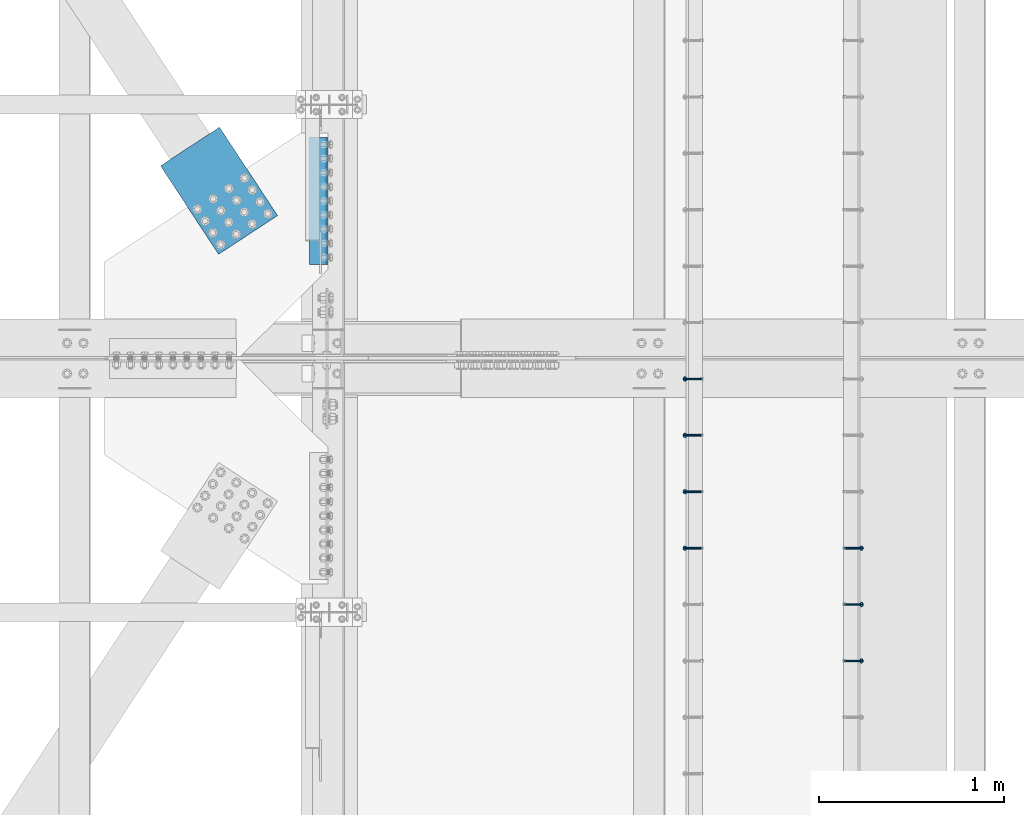
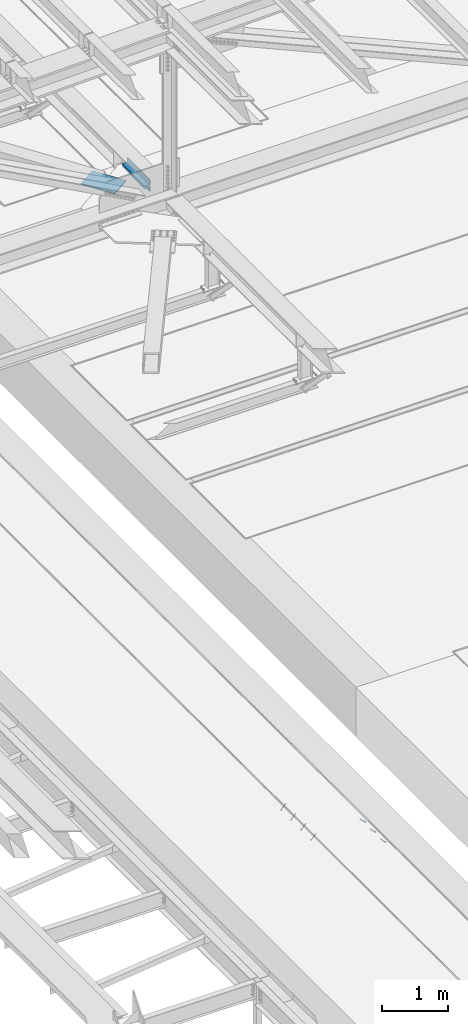
# One storey, part 2203 of 3843: 7 members, 3 beams, 4 elements without a shape of their own.
"""IFC2X3 building model written with IfcOpenShell, lengths in millimetres."""

from ifc_helpers import new_model, si_unit, frame, origin_with_axes, place, context, subcontext, project, spatial, faceted_brep, material, type_object, element, aggregate, save


model = new_model("IFC2X3")

# Units and contexts
model_context = context("Model", 3, precision=1e-05, world=origin_with_axes())
body_context = subcontext(model_context, "Body", "Model", "MODEL_VIEW")
ifc_project = project(units=[si_unit("LENGTHUNIT", "METRE", prefix="MILLI"), si_unit("AREAUNIT", "SQUARE_METRE"), si_unit("VOLUMEUNIT", "CUBIC_METRE"), si_unit("MASSUNIT", "GRAM", prefix="KILO"), si_unit("TIMEUNIT", "SECOND"), si_unit("PLANEANGLEUNIT", "RADIAN"), si_unit("SOLIDANGLEUNIT", "STERADIAN"), si_unit("THERMODYNAMICTEMPERATUREUNIT", "DEGREE_CELSIUS"), si_unit("LUMINOUSINTENSITYUNIT", "LUMEN")], contexts=[model_context])

# Site, building, storey
site_placement = place(None, origin_with_axes())
site = spatial("IfcSite", under=ifc_project, at=site_placement, CompositionType="ELEMENT")
building_placement = place(site_placement, origin_with_axes())
building = spatial("IfcBuilding", under=site, at=building_placement, Name="Undefined", CompositionType="ELEMENT")
storey_placement = place(building_placement, origin_with_axes())
storey = spatial("IfcBuildingStorey", under=building, at=storey_placement, Name="Undefined", CompositionType="ELEMENT", Elevation=0.0)

# Assembly, members
assembly_1_placement = place(storey_placement, origin_with_axes())
assembly_1 = element("IfcElementAssembly", 1, at=assembly_1_placement, inside=storey, Name="EMBED_ANGLE", AssemblyPlace="NOTDEFINED", PredefinedType="RIGID_FRAME")
ifc_material_1 = material(Name="STEEL/A108")
member_type = type_object("IfcMemberType", PredefinedType="NOTDEFINED")
member_1_placement = place(assembly_1_placement, frame((44851.3834999999, 48923.575189209, 30456.1875), z_axis=(0.0, 1.0, 0.0), x_axis=(0.707106781186548, 0.0, -0.707106781186548)))
member_1 = element("IfcMember", 2, at=member_1_placement, type_object=member_type, material=ifc_material_1, Name="HEADED STUD ANCHOR", context=body_context, shape_type="Brep", body=[
    faceted_brep([(7.27595761418343e-12, -3.18000006675175, 5.5), (0.0, -5.49999999998363, 3.1800000667572), (118.110000000976, -5.49999999999091, 3.1800000667572), (118.110000000983, -3.18000006675175, 5.5), (0.0, -6.3499999046162, 0.0), (118.110000000968, -6.34999990461256, 0.0), (0.0, -5.49999999998363, -3.1800000667572), (118.110000000976, -5.49999999999091, -3.1800000667572), (7.27595761418343e-12, -3.18000006675175, -5.5), (118.110000000983, -3.18000006675175, -5.5), (7.27595761418343e-12, -1.81898940354586e-12, -6.34999990463257), (118.110000000968, -1.81898940354586e-12, -6.34999990463257), (0.0, 3.18000006675175, -5.5), (118.110000000968, 3.18000006674811, -5.5), (7.27595761418343e-12, 5.49999999998363, -3.1800000667572), (118.110000000983, 5.49999999998363, -3.1800000667572), (7.27595761418343e-12, 6.3499999046162, 0.0), (118.110000000976, 6.34999990461256, 0.0), (7.27595761418343e-12, 5.49999999998363, 3.1800000667572), (118.110000000983, 5.49999999998363, 3.1800000667572), (0.0, 3.18000006675175, 5.5), (118.110000000968, 3.18000006674811, 5.5), (7.27595761418343e-12, -1.81898940354586e-12, 6.34999990463257), (118.110000000968, -1.81898940354586e-12, 6.34999990463257), (120.650000000991, -10.9899997710909, 6.34999990463257), (120.650000000998, -6.34000015257152, 10.9899997711182), (120.650000000991, -12.6999998092379, 0.0), (120.650000000991, -10.9899997710909, -6.34999990463257), (120.650000000998, -6.34000015257152, -10.9899997711182), (120.650000000991, -1.81898940354586e-12, -12.6899995803833), (120.650000000991, 6.34000015257152, -10.9899997711182), (120.650000000998, 10.9899997710909, -6.34999990463257), (120.650000000991, 12.6999998092342, 0.0), (120.650000000998, 10.9899997710909, 6.34999990463257), (120.650000000991, 6.34000015257152, 10.9899997711182), (120.650000000991, -1.81898940354586e-12, 12.6899995803833), (127.000000001048, -10.9899997710945, 6.34999990463257), (127.000000001048, -6.34000015257152, 10.9899997711182), (127.000000001048, -12.6999998092342, 0.0), (127.000000001048, -10.9899997710945, -6.34999990463257), (127.000000001048, -6.34000015257152, -10.9899997711182), (127.000000001048, 1.81898940354586e-12, -12.6899995803833), (127.000000001048, 6.34000015256788, -10.9899997711182), (127.000000001048, 10.9899997710909, -6.34999990463257), (127.000000001048, 12.6999998092379, 0.0), (127.000000001048, 10.9899997710909, 6.34999990463257), (127.000000001048, 6.34000015256788, 10.9899997711182), (127.000000001048, 1.81898940354586e-12, 12.6899995803833)], [[[0, 1, 2, 3]], [[1, 4, 5, 2]], [[4, 6, 7, 5]], [[6, 8, 9, 7]], [[8, 10, 11, 9]], [[10, 12, 13, 11]], [[12, 14, 15, 13]], [[14, 16, 17, 15]], [[16, 18, 19, 17]], [[18, 20, 21, 19]], [[20, 22, 23, 21]], [[22, 0, 3, 23]], [[22, 20, 18, 16, 14, 12, 10, 8, 6, 4, 1, 0]], [[3, 2, 24, 25]], [[2, 5, 26, 24]], [[5, 7, 27, 26]], [[7, 9, 28, 27]], [[9, 11, 29, 28]], [[11, 13, 30, 29]], [[13, 15, 31, 30]], [[15, 17, 32, 31]], [[17, 19, 33, 32]], [[19, 21, 34, 33]], [[21, 23, 35, 34]], [[23, 3, 25, 35]], [[25, 24, 36, 37]], [[24, 26, 38, 36]], [[26, 27, 39, 38]], [[27, 28, 40, 39]], [[28, 29, 41, 40]], [[29, 30, 42, 41]], [[30, 31, 43, 42]], [[31, 32, 44, 43]], [[32, 33, 45, 44]], [[33, 34, 46, 45]], [[34, 35, 47, 46]], [[35, 25, 37, 47]], [[38, 39, 40, 41, 42, 43, 44, 45, 46, 47, 37, 36]]]),
])
member_2_placement = place(assembly_1_placement, frame((44851.3834999999, 49228.375189209, 30456.1875), z_axis=(0.0, 1.0, 0.0), x_axis=(0.707106781186548, 0.0, -0.707106781186548)))
member_2 = element("IfcMember", 3, at=member_2_placement, type_object=member_type, material=ifc_material_1, Name="HEADED STUD ANCHOR", context=body_context, shape_type="Brep", body=[
    faceted_brep([(7.27595761418343e-12, -3.18000006675175, 5.5), (0.0, -5.49999999998363, 3.1800000667572), (118.110000000976, -5.49999999999091, 3.1800000667572), (118.110000000983, -3.18000006675175, 5.5), (0.0, -6.3499999046162, 0.0), (118.110000000968, -6.34999990461256, 0.0), (0.0, -5.49999999998363, -3.1800000667572), (118.110000000976, -5.49999999999091, -3.1800000667572), (7.27595761418343e-12, -3.18000006675175, -5.5), (118.110000000983, -3.18000006675175, -5.5), (7.27595761418343e-12, -1.81898940354586e-12, -6.34999990463257), (118.110000000968, -1.81898940354586e-12, -6.34999990463257), (0.0, 3.18000006675175, -5.5), (118.110000000968, 3.18000006674811, -5.5), (7.27595761418343e-12, 5.49999999998363, -3.1800000667572), (118.110000000983, 5.49999999998363, -3.1800000667572), (7.27595761418343e-12, 6.3499999046162, 0.0), (118.110000000976, 6.34999990461256, 0.0), (7.27595761418343e-12, 5.49999999998363, 3.1800000667572), (118.110000000983, 5.49999999998363, 3.1800000667572), (0.0, 3.18000006675175, 5.5), (118.110000000968, 3.18000006674811, 5.5), (7.27595761418343e-12, -1.81898940354586e-12, 6.34999990463257), (118.110000000968, -1.81898940354586e-12, 6.34999990463257), (120.650000000991, -10.9899997710909, 6.34999990463257), (120.650000000998, -6.34000015257152, 10.9899997711182), (120.650000000991, -12.6999998092379, 0.0), (120.650000000991, -10.9899997710909, -6.34999990463257), (120.650000000998, -6.34000015257152, -10.9899997711182), (120.650000000991, -1.81898940354586e-12, -12.6899995803833), (120.650000000991, 6.34000015257152, -10.9899997711182), (120.650000000998, 10.9899997710909, -6.34999990463257), (120.650000000991, 12.6999998092342, 0.0), (120.650000000998, 10.9899997710909, 6.34999990463257), (120.650000000991, 6.34000015257152, 10.9899997711182), (120.650000000991, -1.81898940354586e-12, 12.6899995803833), (127.000000001048, -10.9899997710945, 6.34999990463257), (127.000000001048, -6.34000015257152, 10.9899997711182), (127.000000001048, -12.6999998092342, 0.0), (127.000000001048, -10.9899997710945, -6.34999990463257), (127.000000001048, -6.34000015257152, -10.9899997711182), (127.000000001048, 1.81898940354586e-12, -12.6899995803833), (127.000000001048, 6.34000015256788, -10.9899997711182), (127.000000001048, 10.9899997710909, -6.34999990463257), (127.000000001048, 12.6999998092379, 0.0), (127.000000001048, 10.9899997710909, 6.34999990463257), (127.000000001048, 6.34000015256788, 10.9899997711182), (127.000000001048, 1.81898940354586e-12, 12.6899995803833)], [[[0, 1, 2, 3]], [[1, 4, 5, 2]], [[4, 6, 7, 5]], [[6, 8, 9, 7]], [[8, 10, 11, 9]], [[10, 12, 13, 11]], [[12, 14, 15, 13]], [[14, 16, 17, 15]], [[16, 18, 19, 17]], [[18, 20, 21, 19]], [[20, 22, 23, 21]], [[22, 0, 3, 23]], [[22, 20, 18, 16, 14, 12, 10, 8, 6, 4, 1, 0]], [[3, 2, 24, 25]], [[2, 5, 26, 24]], [[5, 7, 27, 26]], [[7, 9, 28, 27]], [[9, 11, 29, 28]], [[11, 13, 30, 29]], [[13, 15, 31, 30]], [[15, 17, 32, 31]], [[17, 19, 33, 32]], [[19, 21, 34, 33]], [[21, 23, 35, 34]], [[23, 3, 25, 35]], [[25, 24, 36, 37]], [[24, 26, 38, 36]], [[26, 27, 39, 38]], [[27, 28, 40, 39]], [[28, 29, 41, 40]], [[29, 30, 42, 41]], [[30, 31, 43, 42]], [[31, 32, 44, 43]], [[32, 33, 45, 44]], [[33, 34, 46, 45]], [[34, 35, 47, 46]], [[35, 25, 37, 47]], [[38, 39, 40, 41, 42, 43, 44, 45, 46, 47, 37, 36]]]),
])
member_3_placement = place(assembly_1_placement, frame((44851.3834999999, 49533.175189209, 30456.1875), z_axis=(0.0, 1.0, 0.0), x_axis=(0.707106781186548, 0.0, -0.707106781186548)))
member_3 = element("IfcMember", 4, at=member_3_placement, type_object=member_type, material=ifc_material_1, Name="HEADED STUD ANCHOR", context=body_context, shape_type="Brep", body=[
    faceted_brep([(7.27595761418343e-12, -3.18000006675175, 5.5), (0.0, -5.49999999998363, 3.1800000667572), (118.110000000976, -5.49999999999091, 3.1800000667572), (118.110000000983, -3.18000006675175, 5.5), (0.0, -6.3499999046162, 0.0), (118.110000000968, -6.34999990461256, 0.0), (0.0, -5.49999999998363, -3.1800000667572), (118.110000000976, -5.49999999999091, -3.1800000667572), (7.27595761418343e-12, -3.18000006675175, -5.5), (118.110000000983, -3.18000006675175, -5.5), (7.27595761418343e-12, -1.81898940354586e-12, -6.34999990463257), (118.110000000968, -1.81898940354586e-12, -6.34999990463257), (0.0, 3.18000006675175, -5.5), (118.110000000968, 3.18000006674811, -5.5), (7.27595761418343e-12, 5.49999999998363, -3.1800000667572), (118.110000000983, 5.49999999998363, -3.1800000667572), (7.27595761418343e-12, 6.3499999046162, 0.0), (118.110000000976, 6.34999990461256, 0.0), (7.27595761418343e-12, 5.49999999998363, 3.1800000667572), (118.110000000983, 5.49999999998363, 3.1800000667572), (0.0, 3.18000006675175, 5.5), (118.110000000968, 3.18000006674811, 5.5), (7.27595761418343e-12, -1.81898940354586e-12, 6.34999990463257), (118.110000000968, -1.81898940354586e-12, 6.34999990463257), (120.650000000991, -10.9899997710909, 6.34999990463257), (120.650000000998, -6.34000015257152, 10.9899997711182), (120.650000000991, -12.6999998092379, 0.0), (120.650000000991, -10.9899997710909, -6.34999990463257), (120.650000000998, -6.34000015257152, -10.9899997711182), (120.650000000991, -1.81898940354586e-12, -12.6899995803833), (120.650000000991, 6.34000015257152, -10.9899997711182), (120.650000000998, 10.9899997710909, -6.34999990463257), (120.650000000991, 12.6999998092342, 0.0), (120.650000000998, 10.9899997710909, 6.34999990463257), (120.650000000991, 6.34000015257152, 10.9899997711182), (120.650000000991, -1.81898940354586e-12, 12.6899995803833), (127.000000001048, -10.9899997710945, 6.34999990463257), (127.000000001048, -6.34000015257152, 10.9899997711182), (127.000000001048, -12.6999998092342, 0.0), (127.000000001048, -10.9899997710945, -6.34999990463257), (127.000000001048, -6.34000015257152, -10.9899997711182), (127.000000001048, 1.81898940354586e-12, -12.6899995803833), (127.000000001048, 6.34000015256788, -10.9899997711182), (127.000000001048, 10.9899997710909, -6.34999990463257), (127.000000001048, 12.6999998092379, 0.0), (127.000000001048, 10.9899997710909, 6.34999990463257), (127.000000001048, 6.34000015256788, 10.9899997711182), (127.000000001048, 1.81898940354586e-12, 12.6899995803833)], [[[0, 1, 2, 3]], [[1, 4, 5, 2]], [[4, 6, 7, 5]], [[6, 8, 9, 7]], [[8, 10, 11, 9]], [[10, 12, 13, 11]], [[12, 14, 15, 13]], [[14, 16, 17, 15]], [[16, 18, 19, 17]], [[18, 20, 21, 19]], [[20, 22, 23, 21]], [[22, 0, 3, 23]], [[22, 20, 18, 16, 14, 12, 10, 8, 6, 4, 1, 0]], [[3, 2, 24, 25]], [[2, 5, 26, 24]], [[5, 7, 27, 26]], [[7, 9, 28, 27]], [[9, 11, 29, 28]], [[11, 13, 30, 29]], [[13, 15, 31, 30]], [[15, 17, 32, 31]], [[17, 19, 33, 32]], [[19, 21, 34, 33]], [[21, 23, 35, 34]], [[23, 3, 25, 35]], [[25, 24, 36, 37]], [[24, 26, 38, 36]], [[26, 27, 39, 38]], [[27, 28, 40, 39]], [[28, 29, 41, 40]], [[29, 30, 42, 41]], [[30, 31, 43, 42]], [[31, 32, 44, 43]], [[32, 33, 45, 44]], [[33, 34, 46, 45]], [[34, 35, 47, 46]], [[35, 25, 37, 47]], [[38, 39, 40, 41, 42, 43, 44, 45, 46, 47, 37, 36]]]),
])
aggregate(assembly_1, [member_1, member_2, member_3])

assembly_2_placement = place(storey_placement, origin_with_axes())
assembly_2 = element("IfcElementAssembly", 5, at=assembly_2_placement, inside=storey, Name="EMBED_ANGLE", AssemblyPlace="NOTDEFINED", PredefinedType="RIGID_FRAME")
member_4_placement = place(assembly_2_placement, frame((44073.5085000003, 49533.175189209, 30456.1874999998), z_axis=(0.0, -1.0, 0.0), x_axis=(-0.707106781186548, 0.0, -0.707106781186548)))
member_4 = element("IfcMember", 6, at=member_4_placement, type_object=member_type, material=ifc_material_1, Name="HEADED STUD ANCHOR", context=body_context, shape_type="Brep", body=[
    faceted_brep([(7.27595761418343e-12, -3.18000006675175, 5.5), (0.0, -5.49999999998363, 3.1800000667572), (118.110000000976, -5.49999999999091, 3.1800000667572), (118.110000000983, -3.18000006675175, 5.5), (0.0, -6.3499999046162, 0.0), (118.110000000968, -6.34999990461256, 0.0), (0.0, -5.49999999998363, -3.1800000667572), (118.110000000976, -5.49999999999091, -3.1800000667572), (7.27595761418343e-12, -3.18000006675175, -5.5), (118.110000000983, -3.18000006675175, -5.5), (7.27595761418343e-12, -1.81898940354586e-12, -6.34999990463257), (118.110000000968, -1.81898940354586e-12, -6.34999990463257), (0.0, 3.18000006675175, -5.5), (118.110000000968, 3.18000006674811, -5.5), (7.27595761418343e-12, 5.49999999998363, -3.1800000667572), (118.110000000983, 5.49999999998363, -3.1800000667572), (7.27595761418343e-12, 6.3499999046162, 0.0), (118.110000000976, 6.34999990461256, 0.0), (7.27595761418343e-12, 5.49999999998363, 3.1800000667572), (118.110000000983, 5.49999999998363, 3.1800000667572), (0.0, 3.18000006675175, 5.5), (118.110000000968, 3.18000006674811, 5.5), (7.27595761418343e-12, -1.81898940354586e-12, 6.34999990463257), (118.110000000968, -1.81898940354586e-12, 6.34999990463257), (120.650000000991, -10.9899997710909, 6.34999990463257), (120.650000000998, -6.34000015257152, 10.9899997711182), (120.650000000991, -12.6999998092379, 0.0), (120.650000000991, -10.9899997710909, -6.34999990463257), (120.650000000998, -6.34000015257152, -10.9899997711182), (120.650000000991, -1.81898940354586e-12, -12.6899995803833), (120.650000000991, 6.34000015257152, -10.9899997711182), (120.650000000998, 10.9899997710909, -6.34999990463257), (120.650000000991, 12.6999998092342, 0.0), (120.650000000998, 10.9899997710909, 6.34999990463257), (120.650000000991, 6.34000015257152, 10.9899997711182), (120.650000000991, -1.81898940354586e-12, 12.6899995803833), (127.000000001048, -10.9899997710945, 6.34999990463257), (127.000000001048, -6.34000015257152, 10.9899997711182), (127.000000001048, -12.6999998092342, 0.0), (127.000000001048, -10.9899997710945, -6.34999990463257), (127.000000001048, -6.34000015257152, -10.9899997711182), (127.000000001048, 1.81898940354586e-12, -12.6899995803833), (127.000000001048, 6.34000015256788, -10.9899997711182), (127.000000001048, 10.9899997710909, -6.34999990463257), (127.000000001048, 12.6999998092379, 0.0), (127.000000001048, 10.9899997710909, 6.34999990463257), (127.000000001048, 6.34000015256788, 10.9899997711182), (127.000000001048, 1.81898940354586e-12, 12.6899995803833)], [[[0, 1, 2, 3]], [[1, 4, 5, 2]], [[4, 6, 7, 5]], [[6, 8, 9, 7]], [[8, 10, 11, 9]], [[10, 12, 13, 11]], [[12, 14, 15, 13]], [[14, 16, 17, 15]], [[16, 18, 19, 17]], [[18, 20, 21, 19]], [[20, 22, 23, 21]], [[22, 0, 3, 23]], [[22, 20, 18, 16, 14, 12, 10, 8, 6, 4, 1, 0]], [[3, 2, 24, 25]], [[2, 5, 26, 24]], [[5, 7, 27, 26]], [[7, 9, 28, 27]], [[9, 11, 29, 28]], [[11, 13, 30, 29]], [[13, 15, 31, 30]], [[15, 17, 32, 31]], [[17, 19, 33, 32]], [[19, 21, 34, 33]], [[21, 23, 35, 34]], [[23, 3, 25, 35]], [[25, 24, 36, 37]], [[24, 26, 38, 36]], [[26, 27, 39, 38]], [[27, 28, 40, 39]], [[28, 29, 41, 40]], [[29, 30, 42, 41]], [[30, 31, 43, 42]], [[31, 32, 44, 43]], [[32, 33, 45, 44]], [[33, 34, 46, 45]], [[34, 35, 47, 46]], [[35, 25, 37, 47]], [[38, 39, 40, 41, 42, 43, 44, 45, 46, 47, 37, 36]]]),
])
member_5_placement = place(assembly_2_placement, frame((44073.5085000003, 49837.975189209, 30456.1874999998), z_axis=(0.0, -1.0, 0.0), x_axis=(-0.707106781186548, 0.0, -0.707106781186548)))
member_5 = element("IfcMember", 7, at=member_5_placement, type_object=member_type, material=ifc_material_1, Name="HEADED STUD ANCHOR", context=body_context, shape_type="Brep", body=[
    faceted_brep([(7.27595761418343e-12, -3.18000006675175, 5.5), (0.0, -5.49999999998363, 3.1800000667572), (118.110000000976, -5.49999999999091, 3.1800000667572), (118.110000000983, -3.18000006675175, 5.5), (0.0, -6.3499999046162, 0.0), (118.110000000968, -6.34999990461256, 0.0), (0.0, -5.49999999998363, -3.1800000667572), (118.110000000976, -5.49999999999091, -3.1800000667572), (7.27595761418343e-12, -3.18000006675175, -5.5), (118.110000000983, -3.18000006675175, -5.5), (7.27595761418343e-12, -1.81898940354586e-12, -6.34999990463257), (118.110000000968, -1.81898940354586e-12, -6.34999990463257), (0.0, 3.18000006675175, -5.5), (118.110000000968, 3.18000006674811, -5.5), (7.27595761418343e-12, 5.49999999998363, -3.1800000667572), (118.110000000983, 5.49999999998363, -3.1800000667572), (7.27595761418343e-12, 6.3499999046162, 0.0), (118.110000000976, 6.34999990461256, 0.0), (7.27595761418343e-12, 5.49999999998363, 3.1800000667572), (118.110000000983, 5.49999999998363, 3.1800000667572), (0.0, 3.18000006675175, 5.5), (118.110000000968, 3.18000006674811, 5.5), (7.27595761418343e-12, -1.81898940354586e-12, 6.34999990463257), (118.110000000968, -1.81898940354586e-12, 6.34999990463257), (120.650000000991, -10.9899997710909, 6.34999990463257), (120.650000000998, -6.34000015257152, 10.9899997711182), (120.650000000991, -12.6999998092379, 0.0), (120.650000000991, -10.9899997710909, -6.34999990463257), (120.650000000998, -6.34000015257152, -10.9899997711182), (120.650000000991, -1.81898940354586e-12, -12.6899995803833), (120.650000000991, 6.34000015257152, -10.9899997711182), (120.650000000998, 10.9899997710909, -6.34999990463257), (120.650000000991, 12.6999998092342, 0.0), (120.650000000998, 10.9899997710909, 6.34999990463257), (120.650000000991, 6.34000015257152, 10.9899997711182), (120.650000000991, -1.81898940354586e-12, 12.6899995803833), (127.000000001048, -10.9899997710945, 6.34999990463257), (127.000000001048, -6.34000015257152, 10.9899997711182), (127.000000001048, -12.6999998092342, 0.0), (127.000000001048, -10.9899997710945, -6.34999990463257), (127.000000001048, -6.34000015257152, -10.9899997711182), (127.000000001048, 1.81898940354586e-12, -12.6899995803833), (127.000000001048, 6.34000015256788, -10.9899997711182), (127.000000001048, 10.9899997710909, -6.34999990463257), (127.000000001048, 12.6999998092379, 0.0), (127.000000001048, 10.9899997710909, 6.34999990463257), (127.000000001048, 6.34000015256788, 10.9899997711182), (127.000000001048, 1.81898940354586e-12, 12.6899995803833)], [[[0, 1, 2, 3]], [[1, 4, 5, 2]], [[4, 6, 7, 5]], [[6, 8, 9, 7]], [[8, 10, 11, 9]], [[10, 12, 13, 11]], [[12, 14, 15, 13]], [[14, 16, 17, 15]], [[16, 18, 19, 17]], [[18, 20, 21, 19]], [[20, 22, 23, 21]], [[22, 0, 3, 23]], [[22, 20, 18, 16, 14, 12, 10, 8, 6, 4, 1, 0]], [[3, 2, 24, 25]], [[2, 5, 26, 24]], [[5, 7, 27, 26]], [[7, 9, 28, 27]], [[9, 11, 29, 28]], [[11, 13, 30, 29]], [[13, 15, 31, 30]], [[15, 17, 32, 31]], [[17, 19, 33, 32]], [[19, 21, 34, 33]], [[21, 23, 35, 34]], [[23, 3, 25, 35]], [[25, 24, 36, 37]], [[24, 26, 38, 36]], [[26, 27, 39, 38]], [[27, 28, 40, 39]], [[28, 29, 41, 40]], [[29, 30, 42, 41]], [[30, 31, 43, 42]], [[31, 32, 44, 43]], [[32, 33, 45, 44]], [[33, 34, 46, 45]], [[34, 35, 47, 46]], [[35, 25, 37, 47]], [[38, 39, 40, 41, 42, 43, 44, 45, 46, 47, 37, 36]]]),
])
member_6_placement = place(assembly_2_placement, frame((44073.5085000003, 50142.775189209, 30456.1874999998), z_axis=(0.0, -1.0, 0.0), x_axis=(-0.707106781186548, 0.0, -0.707106781186548)))
member_6 = element("IfcMember", 8, at=member_6_placement, type_object=member_type, material=ifc_material_1, Name="HEADED STUD ANCHOR", context=body_context, shape_type="Brep", body=[
    faceted_brep([(7.27595761418343e-12, -3.18000006675175, 5.5), (0.0, -5.49999999998363, 3.1800000667572), (118.110000000976, -5.49999999999091, 3.1800000667572), (118.110000000983, -3.18000006675175, 5.5), (0.0, -6.3499999046162, 0.0), (118.110000000968, -6.34999990461256, 0.0), (0.0, -5.49999999998363, -3.1800000667572), (118.110000000976, -5.49999999999091, -3.1800000667572), (7.27595761418343e-12, -3.18000006675175, -5.5), (118.110000000983, -3.18000006675175, -5.5), (7.27595761418343e-12, -1.81898940354586e-12, -6.34999990463257), (118.110000000968, -1.81898940354586e-12, -6.34999990463257), (0.0, 3.18000006675175, -5.5), (118.110000000968, 3.18000006674811, -5.5), (7.27595761418343e-12, 5.49999999998363, -3.1800000667572), (118.110000000983, 5.49999999998363, -3.1800000667572), (7.27595761418343e-12, 6.3499999046162, 0.0), (118.110000000976, 6.34999990461256, 0.0), (7.27595761418343e-12, 5.49999999998363, 3.1800000667572), (118.110000000983, 5.49999999998363, 3.1800000667572), (0.0, 3.18000006675175, 5.5), (118.110000000968, 3.18000006674811, 5.5), (7.27595761418343e-12, -1.81898940354586e-12, 6.34999990463257), (118.110000000968, -1.81898940354586e-12, 6.34999990463257), (120.650000000991, -10.9899997710909, 6.34999990463257), (120.650000000998, -6.34000015257152, 10.9899997711182), (120.650000000991, -12.6999998092379, 0.0), (120.650000000991, -10.9899997710909, -6.34999990463257), (120.650000000998, -6.34000015257152, -10.9899997711182), (120.650000000991, -1.81898940354586e-12, -12.6899995803833), (120.650000000991, 6.34000015257152, -10.9899997711182), (120.650000000998, 10.9899997710909, -6.34999990463257), (120.650000000991, 12.6999998092342, 0.0), (120.650000000998, 10.9899997710909, 6.34999990463257), (120.650000000991, 6.34000015257152, 10.9899997711182), (120.650000000991, -1.81898940354586e-12, 12.6899995803833), (127.000000001048, -10.9899997710945, 6.34999990463257), (127.000000001048, -6.34000015257152, 10.9899997711182), (127.000000001048, -12.6999998092342, 0.0), (127.000000001048, -10.9899997710945, -6.34999990463257), (127.000000001048, -6.34000015257152, -10.9899997711182), (127.000000001048, 1.81898940354586e-12, -12.6899995803833), (127.000000001048, 6.34000015256788, -10.9899997711182), (127.000000001048, 10.9899997710909, -6.34999990463257), (127.000000001048, 12.6999998092379, 0.0), (127.000000001048, 10.9899997710909, 6.34999990463257), (127.000000001048, 6.34000015256788, 10.9899997711182), (127.000000001048, 1.81898940354586e-12, 12.6899995803833)], [[[0, 1, 2, 3]], [[1, 4, 5, 2]], [[4, 6, 7, 5]], [[6, 8, 9, 7]], [[8, 10, 11, 9]], [[10, 12, 13, 11]], [[12, 14, 15, 13]], [[14, 16, 17, 15]], [[16, 18, 19, 17]], [[18, 20, 21, 19]], [[20, 22, 23, 21]], [[22, 0, 3, 23]], [[22, 20, 18, 16, 14, 12, 10, 8, 6, 4, 1, 0]], [[3, 2, 24, 25]], [[2, 5, 26, 24]], [[5, 7, 27, 26]], [[7, 9, 28, 27]], [[9, 11, 29, 28]], [[11, 13, 30, 29]], [[13, 15, 31, 30]], [[15, 17, 32, 31]], [[17, 19, 33, 32]], [[19, 21, 34, 33]], [[21, 23, 35, 34]], [[23, 3, 25, 35]], [[25, 24, 36, 37]], [[24, 26, 38, 36]], [[26, 27, 39, 38]], [[27, 28, 40, 39]], [[28, 29, 41, 40]], [[29, 30, 42, 41]], [[30, 31, 43, 42]], [[31, 32, 44, 43]], [[32, 33, 45, 44]], [[33, 34, 46, 45]], [[34, 35, 47, 46]], [[35, 25, 37, 47]], [[38, 39, 40, 41, 42, 43, 44, 45, 46, 47, 37, 36]]]),
])
member_7_placement = place(assembly_2_placement, frame((44073.5085000003, 50447.575189209, 30456.1874999998), z_axis=(0.0, -1.0, 0.0), x_axis=(-0.707106781186548, 0.0, -0.707106781186548)))
member_7 = element("IfcMember", 9, at=member_7_placement, type_object=member_type, material=ifc_material_1, Name="HEADED STUD ANCHOR", context=body_context, shape_type="Brep", body=[
    faceted_brep([(7.27595761418343e-12, -3.18000006675175, 5.5), (0.0, -5.49999999998363, 3.1800000667572), (118.110000000976, -5.49999999999091, 3.1800000667572), (118.110000000983, -3.18000006675175, 5.5), (0.0, -6.3499999046162, 0.0), (118.110000000968, -6.34999990461256, 0.0), (0.0, -5.49999999998363, -3.1800000667572), (118.110000000976, -5.49999999999091, -3.1800000667572), (7.27595761418343e-12, -3.18000006675175, -5.5), (118.110000000983, -3.18000006675175, -5.5), (7.27595761418343e-12, -1.81898940354586e-12, -6.34999990463257), (118.110000000968, -1.81898940354586e-12, -6.34999990463257), (0.0, 3.18000006675175, -5.5), (118.110000000968, 3.18000006674811, -5.5), (7.27595761418343e-12, 5.49999999998363, -3.1800000667572), (118.110000000983, 5.49999999998363, -3.1800000667572), (7.27595761418343e-12, 6.3499999046162, 0.0), (118.110000000976, 6.34999990461256, 0.0), (7.27595761418343e-12, 5.49999999998363, 3.1800000667572), (118.110000000983, 5.49999999998363, 3.1800000667572), (0.0, 3.18000006675175, 5.5), (118.110000000968, 3.18000006674811, 5.5), (7.27595761418343e-12, -1.81898940354586e-12, 6.34999990463257), (118.110000000968, -1.81898940354586e-12, 6.34999990463257), (120.650000000991, -10.9899997710909, 6.34999990463257), (120.650000000998, -6.34000015257152, 10.9899997711182), (120.650000000991, -12.6999998092379, 0.0), (120.650000000991, -10.9899997710909, -6.34999990463257), (120.650000000998, -6.34000015257152, -10.9899997711182), (120.650000000991, -1.81898940354586e-12, -12.6899995803833), (120.650000000991, 6.34000015257152, -10.9899997711182), (120.650000000998, 10.9899997710909, -6.34999990463257), (120.650000000991, 12.6999998092342, 0.0), (120.650000000998, 10.9899997710909, 6.34999990463257), (120.650000000991, 6.34000015257152, 10.9899997711182), (120.650000000991, -1.81898940354586e-12, 12.6899995803833), (127.000000001048, -10.9899997710945, 6.34999990463257), (127.000000001048, -6.34000015257152, 10.9899997711182), (127.000000001048, -12.6999998092342, 0.0), (127.000000001048, -10.9899997710945, -6.34999990463257), (127.000000001048, -6.34000015257152, -10.9899997711182), (127.000000001048, 1.81898940354586e-12, -12.6899995803833), (127.000000001048, 6.34000015256788, -10.9899997711182), (127.000000001048, 10.9899997710909, -6.34999990463257), (127.000000001048, 12.6999998092379, 0.0), (127.000000001048, 10.9899997710909, 6.34999990463257), (127.000000001048, 6.34000015256788, 10.9899997711182), (127.000000001048, 1.81898940354586e-12, 12.6899995803833)], [[[0, 1, 2, 3]], [[1, 4, 5, 2]], [[4, 6, 7, 5]], [[6, 8, 9, 7]], [[8, 10, 11, 9]], [[10, 12, 13, 11]], [[12, 14, 15, 13]], [[14, 16, 17, 15]], [[16, 18, 19, 17]], [[18, 20, 21, 19]], [[20, 22, 23, 21]], [[22, 0, 3, 23]], [[22, 20, 18, 16, 14, 12, 10, 8, 6, 4, 1, 0]], [[3, 2, 24, 25]], [[2, 5, 26, 24]], [[5, 7, 27, 26]], [[7, 9, 28, 27]], [[9, 11, 29, 28]], [[11, 13, 30, 29]], [[13, 15, 31, 30]], [[15, 17, 32, 31]], [[17, 19, 33, 32]], [[19, 21, 34, 33]], [[21, 23, 35, 34]], [[23, 3, 25, 35]], [[25, 24, 36, 37]], [[24, 26, 38, 36]], [[26, 27, 39, 38]], [[27, 28, 40, 39]], [[28, 29, 41, 40]], [[29, 30, 42, 41]], [[30, 31, 43, 42]], [[31, 32, 44, 43]], [[32, 33, 45, 44]], [[33, 34, 46, 45]], [[34, 35, 47, 46]], [[35, 25, 37, 47]], [[38, 39, 40, 41, 42, 43, 44, 45, 46, 47, 37, 36]]]),
])
aggregate(assembly_2, [member_4, member_5, member_6, member_7])

# Assembly, beams
assembly_3_placement = place(storey_placement, origin_with_axes())
assembly_3 = element("IfcElementAssembly", 10, at=assembly_3_placement, inside=storey, Name="PLATE", AssemblyPlace="NOTDEFINED", PredefinedType="RIGID_FRAME")
ifc_material_2 = material(Name="STEEL/A572-50")
beam_type_1 = type_object("IfcBeamType", Name="L4X4X1/2", PredefinedType="NOTDEFINED")
beam_1_placement = place(assembly_3_placement, frame((42006.8375877249, 51066.699997961, 42297.3500007629), z_axis=(-1.0, 0.0, 0.0), x_axis=(0.0, 1.0, 0.0)))
beam_1 = element("IfcBeam", 11, at=beam_1_placement, type_object=beam_type_1, material=ifc_material_2, Name="ANGLE", ObjectType="L4X4X1/2", context=body_context, shape_type="Brep", body=[
    faceted_brep([(0.0, 50.8000000000029, -50.8000000000029), (0.0, 50.8000000000029, 50.8000000000029), (685.800000000003, 50.8000000000029, 50.8000000000029), (685.800000000003, 50.8000000000029, -50.8000000000029), (0.0, 38.0999999999985, 50.8000000000029), (685.800000000003, 38.0999999999985, 50.8000000000029), (0.0, 38.0999999999985, -38.0999999999985), (685.800000000003, 38.0999999999985, -38.1000000000058), (0.0, -50.8000000000029, -38.1000000000058), (685.800000000003, -50.8000000000029, -38.1000000000058), (0.0, -50.8000000000029, -50.8000000000029), (685.800000000003, -50.8000000000029, -50.8000000000029)], [[[0, 1, 2, 3]], [[1, 4, 5, 2]], [[4, 6, 7, 5]], [[6, 8, 9, 7]], [[8, 10, 11, 9]], [[10, 0, 3, 11]], [[5, 7, 9, 11, 3, 2]], [[10, 8, 6, 4, 1, 0]]]),
])
beam_type_2 = type_object("IfcBeamType", Name="L4X3-1/2X1/2", PredefinedType="NOTDEFINED")
beam_2_placement = place(assembly_3_placement, frame((42006.8375877249, 51752.499997961, 42173.5249984741), z_axis=(-1.0, 0.0, 0.0), x_axis=(0.0, -1.0, 0.0)))
beam_2 = element("IfcBeam", 12, at=beam_2_placement, type_object=beam_type_2, material=ifc_material_2, Name="ANGLE", ObjectType="L4X3-1/2X1/2", context=body_context, shape_type="Brep", body=[
    faceted_brep([(0.0, 44.4499999999971, -50.8000000000029), (0.0, 44.4499999999971, 50.8000000000029), (685.800000000003, 44.4499999999971, 50.8000000000029), (685.800000000003, 44.4499999999971, -50.8000000000029), (0.0, 31.75, 50.8000000000029), (685.800000000003, 31.75, 50.8000000000029), (0.0, 31.7500000838336, -38.0999999999985), (685.800000000003, 31.75, -38.0999999999985), (4.36557456851006e-11, -44.4500000000226, -38.0999999999985), (685.800000000003, -44.4499999999971, -38.0999999999985), (0.0, -44.4499999999971, -50.8000000000029), (685.800000000003, -44.4499999999971, -50.8000000000029)], [[[0, 1, 2, 3]], [[1, 4, 5, 2]], [[4, 6, 7, 5]], [[6, 8, 9, 7]], [[8, 10, 11, 9]], [[10, 0, 3, 11]], [[5, 7, 9, 11, 3, 2]], [[10, 8, 6, 4, 1, 0]]]),
])
aggregate(assembly_3, [beam_2, beam_1])

# Assembly, beam
assembly_4_placement = place(storey_placement, origin_with_axes())
assembly_4 = element("IfcElementAssembly", 13, at=assembly_4_placement, inside=storey, AssemblyPlace="NOTDEFINED", PredefinedType="RIGID_FRAME")
beam_type_3 = type_object("IfcBeamType", PredefinedType="NOTDEFINED")
beam_3_placement = place(assembly_4_placement, frame((41624.4299723945, 51225.7932391682, 42259.25), z_axis=(-0.835938629021657, -0.548822930014219, 0.0), x_axis=(-0.548822930014213, 0.835938629021661, 0.0)))
beam_3 = element("IfcBeam", 14, at=beam_3_placement, type_object=beam_type_3, material=ifc_material_2, Name="PLATE", context=body_context, shape_type="Brep", body=[
    faceted_brep([(5.85714587941766e-10, 12.6999999999971, -190.500000000349), (-6.14818418398499e-10, 12.6999999999971, 190.500000000364), (571.499999996191, 12.6999999999971, 190.49999999936), (571.499999997392, 12.6999999999971, -190.500000001353), (-6.14818418398499e-10, -12.6999999999971, 190.500000000364), (571.499999996191, -12.6999999999971, 190.49999999936), (5.85714587941766e-10, -12.6999999999971, -190.500000000349), (571.499999997392, -12.6999999999971, -190.500000001353)], [[[0, 1, 2, 3]], [[1, 4, 5, 2]], [[4, 6, 7, 5]], [[6, 0, 3, 7]], [[5, 7, 3, 2]], [[6, 4, 1, 0]]]),
])
aggregate(assembly_4, [beam_3])

save(model, "model.ifc")
